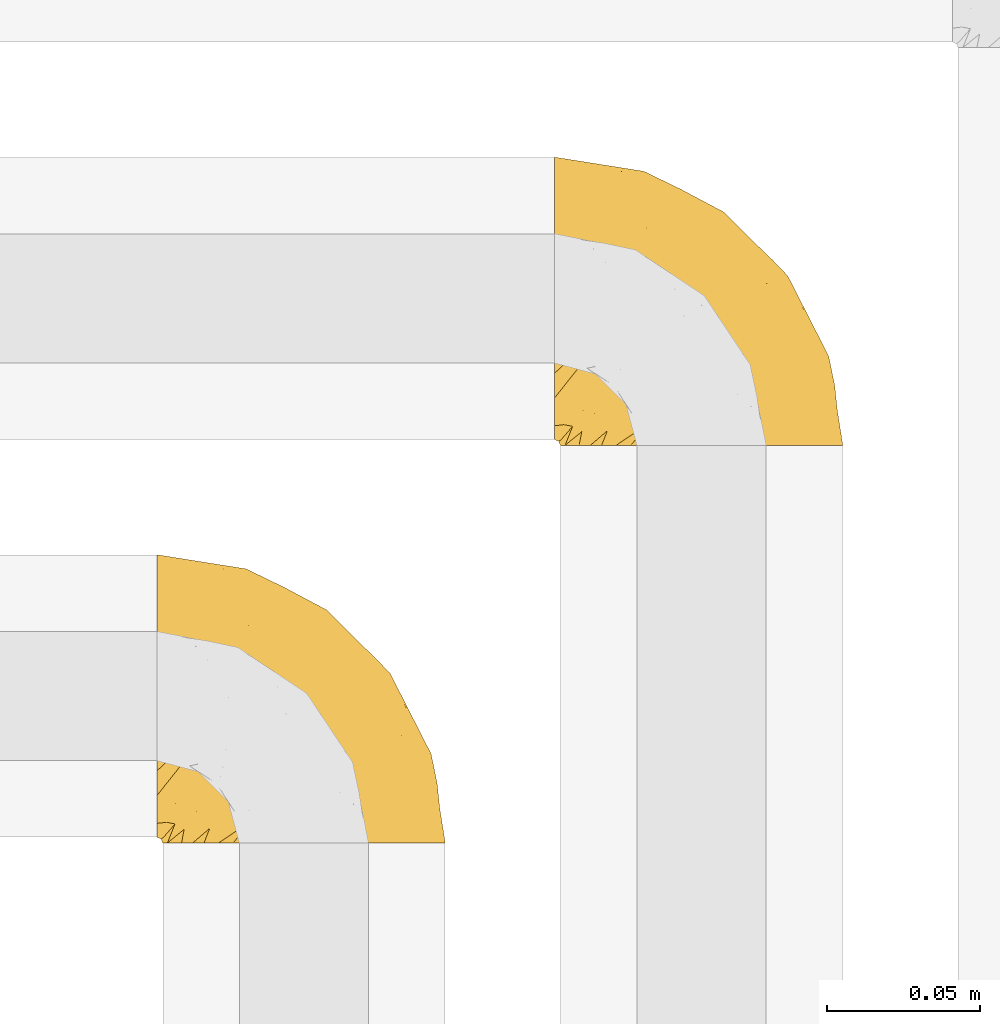
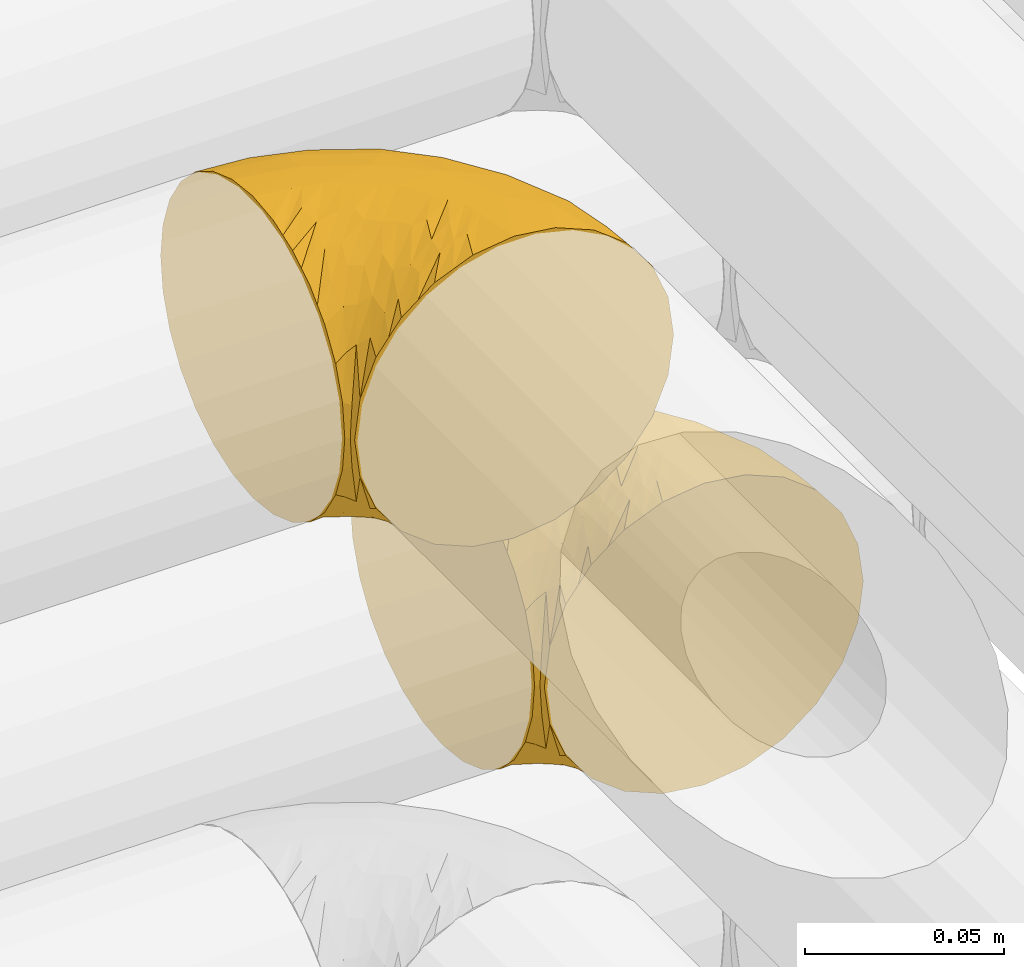
# One storey, part 180 of 827: 2 coverings.
"""IFC2X3 building model written with IfcOpenShell, lengths in millimetres."""

from ifc_helpers import new_model, entity, si_unit, converted_unit, derived_unit, direction, frame, origin, place, context, subcontext, project, spatial, faceted_brep, element, save


model = new_model("IFC2X3")

# Units and contexts
model_context = context("Model", 3, precision=0.01, world=origin(), true_north=direction((6.12303176911189e-17, 1.0)))
body_context = subcontext(model_context, "Body", "Model", "MODEL_VIEW")
ifc_project = project(units=[si_unit("LENGTHUNIT", "METRE", prefix="MILLI"), si_unit("AREAUNIT", "SQUARE_METRE"), si_unit("VOLUMEUNIT", "CUBIC_METRE"), converted_unit("PLANEANGLEUNIT", "DEGREE", entity("IfcRatioMeasure", 0.0174532925199433), si_unit("PLANEANGLEUNIT", "RADIAN"), dimensions=[0, 0, 0, 0, 0, 0, 0]), si_unit("MASSUNIT", "GRAM", prefix="KILO"), derived_unit("MASSDENSITYUNIT", [(si_unit("MASSUNIT", "GRAM", prefix="KILO"), 1), (si_unit("LENGTHUNIT", "METRE"), -3)]), derived_unit("MOMENTOFINERTIAUNIT", [(si_unit("LENGTHUNIT", "METRE"), 4)]), si_unit("TIMEUNIT", "SECOND"), si_unit("FREQUENCYUNIT", "HERTZ"), si_unit("THERMODYNAMICTEMPERATUREUNIT", "DEGREE_CELSIUS"), derived_unit("THERMALTRANSMITTANCEUNIT", [(si_unit("MASSUNIT", "GRAM", prefix="KILO"), 1), (si_unit("THERMODYNAMICTEMPERATUREUNIT", "KELVIN"), -1), (si_unit("TIMEUNIT", "SECOND"), -3)]), derived_unit("VOLUMETRICFLOWRATEUNIT", [(si_unit("LENGTHUNIT", "METRE"), 3), (si_unit("TIMEUNIT", "SECOND"), -1)]), derived_unit("MASSFLOWRATEUNIT", [(si_unit("MASSUNIT", "GRAM", prefix="KILO"), 1), (si_unit("TIMEUNIT", "SECOND"), -1)]), derived_unit("ROTATIONALFREQUENCYUNIT", [(si_unit("TIMEUNIT", "SECOND"), -1)]), si_unit("ELECTRICCURRENTUNIT", "AMPERE"), si_unit("ELECTRICVOLTAGEUNIT", "VOLT"), si_unit("POWERUNIT", "WATT"), si_unit("FORCEUNIT", "NEWTON", prefix="KILO"), si_unit("ILLUMINANCEUNIT", "LUX"), si_unit("LUMINOUSFLUXUNIT", "LUMEN"), si_unit("LUMINOUSINTENSITYUNIT", "CANDELA"), derived_unit("USERDEFINED", [(si_unit("MASSUNIT", "GRAM", prefix="KILO"), -1), (si_unit("LENGTHUNIT", "METRE"), -2), (si_unit("TIMEUNIT", "SECOND"), 3), (si_unit("LUMINOUSFLUXUNIT", "LUMEN"), 1)]), derived_unit("LINEARVELOCITYUNIT", [(si_unit("LENGTHUNIT", "METRE"), 1), (si_unit("TIMEUNIT", "SECOND"), -1)]), si_unit("PRESSUREUNIT", "PASCAL"), derived_unit("USERDEFINED", [(si_unit("LENGTHUNIT", "METRE"), -2), (si_unit("MASSUNIT", "GRAM", prefix="KILO"), 1), (si_unit("TIMEUNIT", "SECOND"), -2)]), derived_unit("LINEARFORCEUNIT", [(si_unit("MASSUNIT", "GRAM", prefix="KILO"), 1), (si_unit("LENGTHUNIT", "METRE"), 1), (si_unit("TIMEUNIT", "SECOND"), -2), (si_unit("LENGTHUNIT", "METRE"), -1)]), derived_unit("PLANARFORCEUNIT", [(si_unit("MASSUNIT", "GRAM", prefix="KILO"), 1), (si_unit("LENGTHUNIT", "METRE"), 1), (si_unit("TIMEUNIT", "SECOND"), -2), (si_unit("LENGTHUNIT", "METRE"), -2)])], contexts=[model_context])

# Site, building, storey
site_placement = place(None, origin())
site = spatial("IfcSite", under=ifc_project, at=site_placement, CompositionType="ELEMENT")
building_placement = place(site_placement, origin())
building = spatial("IfcBuilding", under=site, at=building_placement, CompositionType="ELEMENT")
storey_placement = place(building_placement, frame((0.0, 0.0, 28200.0)))
storey = spatial("IfcBuildingStorey", under=building, at=storey_placement, Name="08", CompositionType="ELEMENT", Elevation=28200.0)

# Coverings
covering_1_placement = place(storey_placement, frame((35420.44, 14180.41, 3152.2)))
element("IfcCovering", 1, at=covering_1_placement, inside=storey, Name=":ADSK_", ObjectType=":ADSK_", PredefinedType="INSULATION", context=body_context, shape_type="Brep", body=[
    faceted_brep([(1.6, 78.41, 83.91), (1.6, 85.72, 76.59), (1.6, 91.22, 67.83), (1.6, 94.64, 58.07), (1.6, 95.8, 47.8), (1.6, 94.64, 37.51), (1.6, 91.22, 27.74), (1.6, 85.71, 18.98), (1.6, 78.39, 11.67), (1.6, 69.63, 6.17), (1.6, 59.87, 2.75), (1.6, 49.6, 1.6), (1.6, 45.45, 2.06), (1.6, 42.38, 2.41), (1.6, 39.31, 2.75), (1.6, 34.43, 4.46), (1.6, 29.54, 6.17), (1.6, 25.16, 8.93), (1.6, 20.78, 11.68), (1.6, 17.13, 15.34), (1.6, 13.47, 19.0), (1.6, 7.97, 27.76), (1.6, 6.26, 32.64), (1.6, 4.55, 37.52), (1.6, 3.4, 47.8), (1.6, 4.55, 58.08), (1.6, 6.26, 62.96), (1.6, 7.97, 67.85), (1.6, 13.48, 76.61), (1.6, 17.14, 80.26), (1.6, 20.8, 83.92), (1.6, 25.18, 86.67), (1.6, 29.56, 89.42), (1.6, 34.44, 91.13), (1.6, 39.32, 92.84), (1.6, 42.39, 93.18), (1.6, 45.45, 93.53), (1.6, 49.6, 94.0), (1.6, 59.88, 92.84), (1.6, 69.65, 89.42), (3.4, 1.6, 47.8), (4.97, 1.6, 35.84), (9.58, 1.6, 24.7), (13.26, 1.6, 19.91), (16.93, 1.6, 15.13), (21.71, 1.6, 11.46), (26.5, 1.6, 7.78), (32.07, 1.6, 5.48), (37.64, 1.6, 3.17), (41.25, 1.6, 2.69), (43.34, 1.6, 2.42), (45.42, 1.6, 2.14), (49.6, 1.6, 1.6), (61.55, 1.6, 3.17), (72.7, 1.6, 7.78), (82.26, 1.6, 15.13), (89.61, 1.6, 24.7), (94.22, 1.6, 35.84), (95.8, 1.6, 47.8), (94.22, 1.6, 59.75), (89.61, 1.6, 70.9), (82.26, 1.6, 80.46), (72.7, 1.6, 87.81), (61.55, 1.6, 92.42), (49.6, 1.6, 94.0), (45.42, 1.6, 93.45), (41.25, 1.6, 92.9), (37.64, 1.6, 92.42), (32.07, 1.6, 90.11), (26.5, 1.6, 87.81), (21.71, 1.6, 84.13), (16.93, 1.6, 80.46), (13.26, 1.6, 75.68), (9.58, 1.6, 70.9), (4.97, 1.6, 59.75), (81.55, 36.81, 71.98), (90.4, 23.28, 63.6), (83.0, 45.8, 59.72), (91.18, 30.7, 47.8), (93.13, 21.2, 55.16), (94.0, 12.96, 47.8), (66.19, 66.19, 63.76), (70.92, 54.51, 72.22), (85.95, 17.98, 74.18), (49.74, 36.69, 92.52), (35.54, 35.54, 94.0), (38.14, 31.64, 94.0), (40.74, 27.75, 94.0), (43.34, 23.86, 94.0), (45.94, 19.96, 94.0), (77.59, 22.8, 82.14), (71.17, 42.67, 80.34), (65.81, 33.21, 87.52), (59.03, 59.45, 79.59), (45.85, 71.5, 78.25), (45.79, 62.66, 85.01), (41.42, 54.5, 90.25), (34.51, 47.57, 93.2), (56.04, 48.81, 87.23), (15.15, 74.98, 85.55), (56.51, 18.7, 93.0), (68.39, 15.75, 89.31), (23.33, 91.17, 61.31), (42.86, 85.28, 56.86), (39.42, 82.58, 68.34), (53.58, 75.78, 65.71), (59.17, 74.98, 56.99), (59.06, 67.27, 72.15), (22.63, 87.38, 70.34), (20.55, 82.04, 78.36), (12.96, 94.0, 47.8), (56.96, 77.8, 47.8), (67.38, 67.38, 47.8), (18.72, 56.2, 93.06), (5.33, 48.85, 94.0), (9.07, 48.11, 94.0), (11.79, 47.57, 94.0), (14.51, 47.03, 94.0), (17.24, 46.48, 94.0), (19.96, 45.94, 94.0), (21.03, 65.78, 89.88), (46.48, 17.24, 94.0), (47.03, 14.51, 94.0), (47.57, 11.79, 94.0), (48.11, 9.07, 94.0), (48.48, 7.2, 94.0), (48.85, 5.33, 94.0), (30.7, 91.18, 47.8), (23.86, 43.34, 94.0), (27.75, 40.74, 94.0), (31.64, 38.14, 94.0), (31.26, 72.73, 83.7), (77.8, 56.96, 47.8), (72.75, 62.23, 55.9), (43.83, 84.49, 47.8), (84.49, 43.83, 47.8), (14.58, 12.05, 81.75), (16.17, 18.95, 86.43), (10.82, 13.02, 79.8), (4.64, 8.34, 69.84), (7.71, 14.63, 79.5), (25.13, 11.09, 88.08), (32.66, 13.66, 91.6), (34.94, 20.08, 92.93), (36.76, 9.61, 92.43), (40.48, 9.48, 93.24), (39.25, 16.1, 93.36), (3.69, 3.42, 57.25), (13.99, 26.63, 89.41), (21.85, 33.72, 92.89), (17.93, 34.77, 92.66), (15.11, 6.75, 79.58), (21.14, 13.31, 86.51), (12.7, 21.11, 86.29), (7.21, 19.94, 83.91), (32.27, 8.67, 90.94), (25.68, 26.11, 91.94), (22.18, 29.3, 91.98), (18.79, 6.32, 82.79), (10.12, 39.92, 93.16), (9.47, 27.05, 88.76), (10.45, 6.04, 73.94), (11.29, 34.4, 91.89), (2.87, 2.87, 47.8), (31.16, 20.92, 92.22), (6.31, 27.43, 88.56), (25.62, 7.54, 87.72), (21.18, 18.45, 88.33), (28.81, 23.88, 92.18), (7.45, 7.77, 71.78), (21.14, 13.3, 9.09), (25.13, 11.09, 7.51), (18.79, 6.33, 12.8), (48.11, 9.07, 1.6), (48.85, 5.33, 1.6), (47.03, 14.51, 1.6), (47.57, 11.79, 1.6), (3.69, 3.42, 38.35), (7.44, 7.76, 23.84), (14.51, 47.03, 1.6), (11.79, 47.57, 1.6), (5.33, 48.85, 1.6), (9.07, 48.11, 1.6), (7.71, 14.62, 16.1), (9.47, 27.03, 6.84), (34.94, 20.08, 2.66), (31.16, 20.92, 3.37), (40.74, 27.75, 1.6), (38.14, 31.64, 1.6), (36.76, 9.61, 3.16), (40.48, 9.48, 2.35), (4.63, 8.33, 25.77), (15.11, 6.74, 16.02), (14.58, 12.04, 13.85), (43.34, 23.86, 1.6), (45.94, 19.96, 1.6), (39.25, 16.1, 2.23), (7.21, 19.93, 11.69), (12.69, 21.1, 9.31), (10.14, 39.92, 2.43), (21.81, 33.68, 2.71), (22.19, 29.28, 3.61), (14.0, 26.62, 6.18), (25.69, 26.08, 3.66), (16.17, 18.93, 9.17), (6.66, 27.87, 6.77), (17.92, 34.75, 2.93), (10.45, 6.04, 21.66), (31.64, 38.14, 1.6), (10.64, 12.79, 16.09), (11.31, 34.41, 3.7), (19.96, 45.94, 1.6), (23.86, 43.34, 1.6), (27.75, 40.74, 1.6), (32.66, 13.66, 3.99), (46.48, 17.24, 1.6), (32.27, 8.67, 4.65), (35.54, 35.54, 1.6), (28.77, 23.83, 3.43), (21.17, 18.43, 7.27), (23.36, 6.03, 9.46), (17.24, 46.48, 1.6), (47.58, 34.52, 2.4), (93.13, 21.2, 40.43), (77.44, 23.82, 13.57), (66.78, 41.32, 11.3), (71.68, 47.62, 18.65), (74.96, 52.66, 27.26), (81.55, 36.81, 23.61), (36.7, 49.75, 3.07), (56.9, 19.07, 2.69), (83.0, 45.8, 35.87), (90.4, 23.28, 31.99), (67.83, 21.35, 6.71), (85.95, 17.98, 21.41), (39.41, 82.57, 27.24), (23.33, 91.17, 34.26), (42.87, 85.27, 38.73), (53.92, 73.89, 26.97), (66.19, 66.19, 31.83), (64.12, 62.43, 23.4), (33.13, 63.53, 6.91), (23.1, 58.45, 3.4), (16.98, 67.16, 5.84), (55.72, 76.72, 35.73), (72.75, 62.22, 39.69), (23.77, 81.54, 17.6), (18.41, 74.8, 10.38), (43.7, 75.83, 20.6), (54.53, 41.45, 5.36), (17.73, 88.2, 24.84), (38.98, 71.6, 13.87), (50.28, 56.23, 9.06), (59.02, 59.44, 15.99)], [[[0, 1, 2, 3, 4, 5, 6, 7, 8, 9, 10, 11, 12, 13, 14, 15, 16, 17, 18, 19, 20, 21, 22, 23, 24, 25, 26, 27, 28, 29, 30, 31, 32, 33, 34, 35, 36, 37, 38, 39]], [[40, 41, 42, 43, 44, 45, 46, 47, 48, 49, 50, 51, 52, 53, 54, 55, 56, 57, 58, 59, 60, 61, 62, 63, 64, 65, 66, 67, 68, 69, 70, 71, 72, 73, 74]], [[75, 76, 77]], [[78, 79, 80]], [[77, 81, 82]], [[76, 75, 83]], [[84, 85, 86, 87, 88, 89]], [[90, 91, 92]], [[76, 60, 59]], [[93, 94, 95]], [[90, 62, 61]], [[83, 61, 60]], [[96, 97, 84]], [[98, 93, 95]], [[0, 39, 99]], [[100, 84, 89]], [[62, 101, 63]], [[2, 102, 3]], [[92, 84, 100]], [[103, 102, 104]], [[103, 105, 106]], [[93, 107, 94]], [[1, 108, 2]], [[92, 101, 90]], [[108, 1, 109]], [[102, 110, 3]], [[93, 82, 107]], [[102, 108, 104]], [[111, 106, 112]], [[109, 0, 99]], [[113, 37, 114, 115, 116, 117, 118, 119]], [[120, 38, 113]], [[100, 89, 121, 122, 123, 124, 125, 126, 64]], [[127, 102, 103]], [[97, 119, 128, 129, 130, 85]], [[99, 120, 131]], [[132, 133, 77]], [[59, 80, 79]], [[1, 0, 109]], [[98, 84, 92]], [[94, 109, 131]], [[120, 39, 38]], [[93, 91, 82]], [[104, 94, 105]], [[97, 113, 119]], [[95, 120, 96]], [[83, 90, 61]], [[91, 93, 98]], [[64, 63, 100]], [[100, 63, 101]], [[77, 76, 79]], [[133, 106, 81]], [[84, 97, 85]], [[113, 96, 120]], [[113, 97, 96]], [[37, 113, 38]], [[110, 102, 127]], [[110, 4, 3]], [[103, 111, 134, 127]], [[90, 75, 91]], [[82, 81, 107]], [[91, 75, 82]], [[77, 82, 75]], [[76, 83, 60]], [[90, 83, 75]], [[105, 107, 81]], [[94, 131, 95]], [[105, 94, 107]], [[109, 94, 104]], [[120, 95, 131]], [[98, 95, 96]], [[84, 98, 96]], [[98, 92, 91]], [[106, 105, 81]], [[103, 104, 105]], [[112, 106, 133]], [[103, 106, 111]], [[112, 133, 132]], [[81, 77, 133]], [[77, 78, 135, 132]], [[120, 99, 39]], [[109, 99, 131]], [[59, 58, 80]], [[59, 79, 76]], [[90, 101, 62]], [[100, 101, 92]], [[2, 108, 102]], [[109, 104, 108]], [[78, 77, 79]], [[136, 137, 138]], [[27, 139, 140]], [[141, 142, 143]], [[144, 145, 121]], [[146, 89, 88]], [[147, 139, 25]], [[148, 149, 150]], [[136, 151, 152]], [[147, 40, 74]], [[24, 147, 25]], [[140, 153, 154]], [[33, 116, 34]], [[73, 72, 151]], [[114, 37, 36, 35, 34, 116, 115]], [[146, 155, 144]], [[156, 85, 130]], [[157, 149, 148]], [[151, 158, 152]], [[117, 33, 159]], [[29, 154, 160]], [[161, 74, 73]], [[162, 128, 119]], [[66, 65, 64, 126, 125, 124, 123, 122, 67]], [[163, 147, 24]], [[27, 140, 28]], [[149, 129, 150]], [[139, 27, 26, 25]], [[68, 144, 69]], [[129, 128, 150]], [[164, 87, 86]], [[130, 129, 149]], [[122, 145, 67]], [[154, 153, 148]], [[162, 119, 159]], [[165, 30, 160]], [[150, 160, 148]], [[128, 162, 150]], [[30, 165, 31]], [[145, 144, 68]], [[89, 146, 144]], [[87, 164, 143]], [[166, 155, 142]], [[88, 87, 143]], [[162, 160, 150]], [[160, 30, 29]], [[154, 29, 28]], [[140, 154, 28]], [[160, 154, 148]], [[140, 137, 153]], [[157, 148, 153]], [[156, 130, 157]], [[153, 137, 157]], [[157, 137, 156]], [[167, 137, 136]], [[168, 85, 156]], [[152, 168, 167]], [[167, 168, 156]], [[164, 152, 141]], [[71, 158, 72]], [[152, 167, 136]], [[88, 142, 146]], [[144, 155, 69]], [[146, 142, 155]], [[70, 166, 71]], [[142, 141, 166]], [[70, 69, 155]], [[141, 158, 71]], [[161, 73, 151]], [[138, 137, 140]], [[161, 136, 169]], [[136, 161, 151]], [[74, 161, 169]], [[152, 158, 141]], [[151, 72, 158]], [[168, 152, 164]], [[137, 167, 156]], [[164, 86, 168]], [[85, 168, 86]], [[116, 33, 117]], [[130, 149, 157]], [[67, 145, 68]], [[121, 89, 144]], [[145, 122, 121]], [[40, 147, 163]], [[169, 147, 74]], [[159, 33, 32]], [[162, 159, 32]], [[159, 119, 118, 117]], [[139, 147, 169]], [[139, 169, 138]], [[162, 32, 31]], [[141, 143, 164]], [[88, 143, 142]], [[71, 166, 141]], [[155, 166, 70]], [[139, 138, 140]], [[169, 136, 138]], [[160, 162, 165]], [[162, 31, 165]], [[170, 171, 172]], [[173, 174, 52, 51, 50, 49, 48, 175, 176]], [[177, 178, 41]], [[179, 15, 180]], [[12, 11, 181, 182, 180, 14, 13]], [[183, 21, 20]], [[19, 18, 184]], [[185, 186, 187]], [[186, 188, 187]], [[43, 172, 44]], [[189, 190, 47]], [[23, 22, 21, 191]], [[170, 192, 193]], [[40, 163, 177]], [[194, 195, 196]], [[24, 23, 177]], [[197, 198, 183]], [[199, 15, 179]], [[47, 46, 189]], [[200, 201, 202]], [[201, 203, 204]], [[205, 206, 184]], [[207, 41, 178]], [[16, 15, 199]], [[14, 180, 15]], [[202, 201, 198]], [[208, 201, 200]], [[163, 24, 177]], [[48, 47, 190]], [[196, 195, 189]], [[197, 184, 202]], [[204, 193, 209]], [[210, 211, 212]], [[206, 212, 213]], [[205, 17, 210]], [[184, 206, 202]], [[210, 212, 206]], [[185, 194, 214]], [[189, 215, 190]], [[216, 45, 214]], [[186, 171, 170]], [[189, 216, 196]], [[197, 20, 19]], [[194, 185, 187]], [[197, 183, 20]], [[184, 197, 19]], [[197, 202, 198]], [[206, 200, 202]], [[204, 183, 198]], [[201, 208, 203]], [[203, 208, 217]], [[204, 198, 201]], [[217, 188, 218]], [[193, 219, 170]], [[171, 186, 185]], [[170, 218, 186]], [[170, 219, 218]], [[42, 207, 192]], [[171, 220, 172]], [[216, 189, 46]], [[214, 194, 196]], [[44, 220, 45]], [[214, 196, 216]], [[216, 46, 45]], [[214, 45, 220]], [[192, 43, 42]], [[204, 203, 219]], [[207, 193, 192]], [[209, 193, 178]], [[41, 207, 42]], [[193, 207, 178]], [[43, 192, 172]], [[170, 172, 192]], [[204, 219, 193]], [[219, 203, 218]], [[217, 218, 203]], [[188, 186, 218]], [[206, 213, 200]], [[208, 200, 213]], [[199, 210, 16]], [[215, 189, 195]], [[215, 175, 190]], [[175, 48, 190]], [[199, 179, 221, 211]], [[210, 199, 211]], [[23, 191, 177]], [[40, 177, 41]], [[178, 177, 191]], [[21, 183, 191]], [[209, 191, 183]], [[205, 18, 17]], [[17, 16, 210]], [[171, 185, 214]], [[172, 220, 44]], [[214, 220, 171]], [[191, 209, 178]], [[204, 209, 183]], [[206, 205, 210]], [[18, 205, 184]], [[222, 195, 194, 187, 188, 217]], [[57, 223, 80]], [[224, 225, 226]], [[226, 227, 228]], [[229, 217, 208, 213, 212, 211]], [[230, 52, 174, 173, 176, 175, 215, 195]], [[231, 232, 228]], [[231, 78, 223]], [[223, 57, 232]], [[224, 233, 225]], [[233, 54, 53]], [[234, 232, 56]], [[56, 55, 234]], [[234, 224, 228]], [[235, 236, 237]], [[224, 55, 54]], [[238, 239, 240]], [[52, 230, 53]], [[241, 242, 243]], [[239, 244, 245]], [[11, 10, 242]], [[236, 6, 5]], [[7, 246, 8]], [[8, 247, 9]], [[238, 248, 235]], [[222, 229, 249]], [[242, 211, 221, 179, 180, 182, 181, 11]], [[233, 53, 230]], [[111, 112, 244]], [[250, 6, 236]], [[247, 251, 241]], [[6, 250, 7]], [[127, 236, 110]], [[249, 229, 252]], [[247, 8, 246]], [[235, 246, 250]], [[236, 5, 110]], [[235, 244, 238]], [[237, 236, 127]], [[243, 9, 247]], [[252, 229, 241]], [[56, 232, 57]], [[222, 230, 195]], [[225, 249, 252]], [[249, 233, 230]], [[54, 233, 224]], [[231, 228, 227]], [[245, 132, 231]], [[249, 225, 233]], [[226, 225, 253]], [[235, 250, 236]], [[246, 7, 250]], [[251, 247, 246]], [[243, 247, 241]], [[248, 246, 235]], [[252, 251, 253]], [[229, 222, 217]], [[230, 222, 249]], [[5, 4, 110]], [[237, 127, 134, 111]], [[238, 244, 239]], [[224, 234, 55]], [[232, 234, 228]], [[242, 241, 229]], [[10, 9, 243]], [[211, 242, 229]], [[10, 243, 242]], [[80, 223, 78]], [[80, 58, 57]], [[231, 223, 232]], [[227, 240, 239]], [[224, 226, 228]], [[240, 226, 253]], [[227, 239, 245]], [[226, 240, 227]], [[251, 248, 253]], [[240, 253, 248]], [[244, 235, 237]], [[237, 111, 244]], [[132, 245, 112]], [[112, 245, 244]], [[135, 78, 231, 132]], [[227, 245, 231]], [[248, 238, 240]], [[246, 248, 251]], [[251, 252, 241]], [[225, 252, 253]]]),
])
covering_2_placement = place(storey_placement, frame((35290.44, 14050.41, 3352.2)))
element("IfcCovering", 2, at=covering_2_placement, inside=storey, Name=":ADSK_", ObjectType=":ADSK_", PredefinedType="INSULATION", context=body_context, shape_type="Brep", body=[
    faceted_brep([(1.6, 78.41, 83.91), (1.6, 85.72, 76.59), (1.6, 91.22, 67.83), (1.6, 94.64, 58.07), (1.6, 95.8, 47.8), (1.6, 94.64, 37.51), (1.6, 91.22, 27.74), (1.6, 85.71, 18.98), (1.6, 78.39, 11.67), (1.6, 69.63, 6.17), (1.6, 59.87, 2.75), (1.6, 49.6, 1.6), (1.6, 45.45, 2.06), (1.6, 42.38, 2.41), (1.6, 39.31, 2.75), (1.6, 34.43, 4.46), (1.6, 29.54, 6.17), (1.6, 25.16, 8.93), (1.6, 20.78, 11.68), (1.6, 17.13, 15.34), (1.6, 13.47, 19.0), (1.6, 7.97, 27.76), (1.6, 6.26, 32.64), (1.6, 4.55, 37.52), (1.6, 3.4, 47.8), (1.6, 4.55, 58.08), (1.6, 6.26, 62.96), (1.6, 7.97, 67.85), (1.6, 13.48, 76.61), (1.6, 17.14, 80.26), (1.6, 20.8, 83.92), (1.6, 25.18, 86.67), (1.6, 29.56, 89.42), (1.6, 34.44, 91.13), (1.6, 39.32, 92.84), (1.6, 42.39, 93.18), (1.6, 45.45, 93.53), (1.6, 49.6, 94.0), (1.6, 59.88, 92.84), (1.6, 69.65, 89.42), (3.4, 1.6, 47.8), (4.97, 1.6, 35.84), (9.58, 1.6, 24.7), (13.26, 1.6, 19.91), (16.93, 1.6, 15.13), (21.71, 1.6, 11.46), (26.5, 1.6, 7.78), (32.07, 1.6, 5.48), (37.64, 1.6, 3.17), (41.25, 1.6, 2.69), (43.34, 1.6, 2.42), (45.42, 1.6, 2.14), (49.6, 1.6, 1.6), (61.55, 1.6, 3.17), (72.7, 1.6, 7.78), (82.26, 1.6, 15.13), (89.61, 1.6, 24.7), (94.22, 1.6, 35.84), (95.8, 1.6, 47.8), (94.22, 1.6, 59.75), (89.61, 1.6, 70.9), (82.26, 1.6, 80.46), (72.7, 1.6, 87.81), (61.55, 1.6, 92.42), (49.6, 1.6, 94.0), (45.42, 1.6, 93.45), (41.25, 1.6, 92.9), (37.64, 1.6, 92.42), (32.07, 1.6, 90.11), (26.5, 1.6, 87.81), (21.71, 1.6, 84.13), (16.93, 1.6, 80.46), (13.26, 1.6, 75.68), (9.58, 1.6, 70.9), (4.97, 1.6, 59.75), (81.55, 36.81, 71.98), (90.4, 23.28, 63.6), (83.0, 45.8, 59.72), (91.18, 30.7, 47.8), (93.13, 21.2, 55.16), (94.0, 12.96, 47.8), (66.19, 66.19, 63.76), (70.92, 54.51, 72.22), (85.95, 17.98, 74.18), (49.74, 36.69, 92.52), (35.54, 35.54, 94.0), (38.14, 31.64, 94.0), (40.74, 27.75, 94.0), (43.34, 23.86, 94.0), (45.94, 19.96, 94.0), (77.59, 22.8, 82.14), (71.17, 42.67, 80.34), (65.81, 33.21, 87.52), (59.03, 59.45, 79.59), (45.85, 71.5, 78.25), (45.79, 62.66, 85.01), (41.42, 54.5, 90.25), (34.51, 47.57, 93.2), (56.04, 48.81, 87.23), (15.15, 74.98, 85.55), (56.51, 18.7, 93.0), (68.39, 15.75, 89.31), (23.33, 91.17, 61.31), (42.86, 85.28, 56.86), (39.42, 82.58, 68.34), (53.58, 75.78, 65.71), (59.17, 74.98, 56.99), (59.06, 67.27, 72.15), (22.63, 87.38, 70.34), (20.55, 82.04, 78.36), (12.96, 94.0, 47.8), (56.96, 77.8, 47.8), (67.38, 67.38, 47.8), (18.72, 56.2, 93.06), (5.33, 48.85, 94.0), (9.07, 48.11, 94.0), (11.79, 47.57, 94.0), (14.51, 47.03, 94.0), (17.24, 46.48, 94.0), (19.96, 45.94, 94.0), (21.03, 65.78, 89.88), (46.48, 17.24, 94.0), (47.03, 14.51, 94.0), (47.57, 11.79, 94.0), (48.11, 9.07, 94.0), (48.48, 7.2, 94.0), (48.85, 5.33, 94.0), (30.7, 91.18, 47.8), (23.86, 43.34, 94.0), (27.75, 40.74, 94.0), (31.64, 38.14, 94.0), (31.26, 72.73, 83.7), (77.8, 56.96, 47.8), (72.75, 62.23, 55.9), (43.83, 84.49, 47.8), (84.49, 43.83, 47.8), (14.58, 12.05, 81.75), (16.17, 18.95, 86.43), (10.82, 13.02, 79.8), (4.64, 8.34, 69.84), (7.71, 14.63, 79.5), (25.13, 11.09, 88.08), (32.66, 13.66, 91.6), (34.94, 20.08, 92.93), (36.76, 9.61, 92.43), (40.48, 9.48, 93.24), (39.25, 16.1, 93.36), (3.69, 3.42, 57.25), (13.99, 26.63, 89.41), (21.85, 33.72, 92.89), (17.93, 34.77, 92.66), (15.11, 6.75, 79.58), (21.14, 13.31, 86.51), (12.7, 21.11, 86.29), (7.21, 19.94, 83.91), (32.27, 8.67, 90.94), (25.68, 26.11, 91.94), (22.18, 29.3, 91.98), (18.79, 6.32, 82.79), (10.12, 39.92, 93.16), (9.47, 27.05, 88.76), (10.45, 6.04, 73.94), (11.29, 34.4, 91.89), (2.87, 2.87, 47.8), (31.16, 20.92, 92.22), (6.31, 27.43, 88.56), (25.62, 7.54, 87.72), (21.18, 18.45, 88.33), (28.81, 23.88, 92.18), (7.45, 7.77, 71.78), (21.17, 18.43, 7.27), (16.17, 18.93, 9.17), (25.69, 26.08, 3.66), (48.11, 9.07, 1.6), (48.85, 5.33, 1.6), (47.03, 14.51, 1.6), (47.57, 11.79, 1.6), (3.69, 3.42, 38.35), (7.44, 7.76, 23.84), (14.51, 47.03, 1.6), (11.79, 47.57, 1.6), (5.33, 48.85, 1.6), (9.07, 48.11, 1.6), (7.71, 14.62, 16.1), (9.47, 27.03, 6.84), (34.94, 20.08, 2.66), (31.16, 20.92, 3.37), (40.74, 27.75, 1.6), (38.14, 31.64, 1.6), (18.79, 6.33, 12.8), (36.76, 9.61, 3.16), (40.48, 9.48, 2.35), (4.63, 8.33, 25.77), (21.14, 13.3, 9.09), (15.11, 6.74, 16.02), (14.58, 12.04, 13.85), (43.34, 23.86, 1.6), (45.94, 19.96, 1.6), (39.25, 16.1, 2.23), (7.21, 19.93, 11.69), (12.69, 21.1, 9.31), (10.14, 39.92, 2.43), (21.81, 33.68, 2.71), (22.19, 29.28, 3.61), (14.0, 26.62, 6.18), (6.66, 27.87, 6.77), (17.92, 34.75, 2.93), (10.45, 6.04, 21.66), (31.64, 38.14, 1.6), (10.64, 12.79, 16.09), (11.31, 34.41, 3.7), (19.96, 45.94, 1.6), (23.86, 43.34, 1.6), (27.75, 40.74, 1.6), (32.66, 13.66, 3.99), (46.48, 17.24, 1.6), (32.27, 8.67, 4.65), (25.13, 11.09, 7.51), (35.54, 35.54, 1.6), (28.77, 23.83, 3.43), (23.36, 6.03, 9.46), (17.24, 46.48, 1.6), (47.58, 34.52, 2.4), (93.13, 21.2, 40.43), (77.44, 23.82, 13.57), (66.78, 41.32, 11.3), (71.68, 47.62, 18.65), (74.96, 52.66, 27.26), (81.55, 36.81, 23.61), (36.7, 49.75, 3.07), (56.9, 19.07, 2.69), (83.0, 45.8, 35.87), (90.4, 23.28, 31.99), (67.83, 21.35, 6.71), (85.95, 17.98, 21.41), (39.41, 82.57, 27.24), (23.33, 91.17, 34.26), (42.87, 85.27, 38.73), (53.92, 73.89, 26.97), (66.19, 66.19, 31.83), (64.12, 62.43, 23.4), (33.13, 63.53, 6.91), (23.1, 58.45, 3.4), (16.98, 67.16, 5.84), (72.75, 62.22, 39.69), (23.77, 81.54, 17.6), (18.41, 74.8, 10.38), (43.7, 75.83, 20.6), (54.53, 41.45, 5.36), (55.72, 76.72, 35.73), (17.73, 88.2, 24.84), (38.98, 71.6, 13.87), (50.28, 56.23, 9.06), (59.02, 59.44, 15.99)], [[[0, 1, 2, 3, 4, 5, 6, 7, 8, 9, 10, 11, 12, 13, 14, 15, 16, 17, 18, 19, 20, 21, 22, 23, 24, 25, 26, 27, 28, 29, 30, 31, 32, 33, 34, 35, 36, 37, 38, 39]], [[40, 41, 42, 43, 44, 45, 46, 47, 48, 49, 50, 51, 52, 53, 54, 55, 56, 57, 58, 59, 60, 61, 62, 63, 64, 65, 66, 67, 68, 69, 70, 71, 72, 73, 74]], [[75, 76, 77]], [[78, 79, 80]], [[77, 81, 82]], [[76, 75, 83]], [[84, 85, 86, 87, 88, 89]], [[90, 91, 92]], [[76, 60, 59]], [[93, 94, 95]], [[90, 62, 61]], [[83, 61, 60]], [[96, 97, 84]], [[98, 93, 95]], [[0, 39, 99]], [[100, 84, 89]], [[62, 101, 63]], [[2, 102, 3]], [[92, 84, 100]], [[103, 102, 104]], [[103, 105, 106]], [[93, 107, 94]], [[1, 108, 2]], [[92, 101, 90]], [[108, 1, 109]], [[102, 110, 3]], [[93, 82, 107]], [[102, 108, 104]], [[111, 106, 112]], [[109, 0, 99]], [[113, 37, 114, 115, 116, 117, 118, 119]], [[120, 38, 113]], [[100, 89, 121, 122, 123, 124, 125, 126, 64]], [[127, 102, 103]], [[97, 119, 128, 129, 130, 85]], [[99, 120, 131]], [[132, 133, 77]], [[59, 80, 79]], [[1, 0, 109]], [[98, 84, 92]], [[94, 109, 131]], [[120, 39, 38]], [[93, 91, 82]], [[104, 94, 105]], [[97, 113, 119]], [[95, 120, 96]], [[83, 90, 61]], [[91, 93, 98]], [[64, 63, 100]], [[100, 63, 101]], [[77, 76, 79]], [[133, 106, 81]], [[84, 97, 85]], [[113, 96, 120]], [[113, 97, 96]], [[37, 113, 38]], [[110, 102, 127]], [[110, 4, 3]], [[103, 111, 134, 127]], [[90, 75, 91]], [[82, 81, 107]], [[91, 75, 82]], [[77, 82, 75]], [[76, 83, 60]], [[90, 83, 75]], [[105, 107, 81]], [[94, 131, 95]], [[105, 94, 107]], [[109, 94, 104]], [[120, 95, 131]], [[98, 95, 96]], [[84, 98, 96]], [[98, 92, 91]], [[106, 105, 81]], [[103, 104, 105]], [[112, 106, 133]], [[103, 106, 111]], [[112, 133, 132]], [[81, 77, 133]], [[77, 78, 135, 132]], [[120, 99, 39]], [[109, 99, 131]], [[59, 58, 80]], [[59, 79, 76]], [[90, 101, 62]], [[100, 101, 92]], [[2, 108, 102]], [[109, 104, 108]], [[78, 77, 79]], [[136, 137, 138]], [[27, 139, 140]], [[141, 142, 143]], [[144, 145, 121]], [[146, 89, 88]], [[147, 139, 25]], [[148, 149, 150]], [[136, 151, 152]], [[147, 40, 74]], [[24, 147, 25]], [[140, 153, 154]], [[33, 116, 34]], [[73, 72, 151]], [[114, 37, 36, 35, 34, 116, 115]], [[146, 155, 144]], [[156, 85, 130]], [[157, 149, 148]], [[151, 158, 152]], [[117, 33, 159]], [[29, 154, 160]], [[161, 74, 73]], [[162, 128, 119]], [[66, 65, 64, 126, 125, 124, 123, 122, 67]], [[163, 147, 24]], [[27, 140, 28]], [[149, 129, 150]], [[139, 27, 26, 25]], [[68, 144, 69]], [[129, 128, 150]], [[164, 87, 86]], [[130, 129, 149]], [[122, 145, 67]], [[154, 153, 148]], [[162, 119, 159]], [[165, 30, 160]], [[150, 160, 148]], [[128, 162, 150]], [[30, 165, 31]], [[145, 144, 68]], [[89, 146, 144]], [[87, 164, 143]], [[166, 155, 142]], [[88, 87, 143]], [[162, 160, 150]], [[160, 30, 29]], [[154, 29, 28]], [[140, 154, 28]], [[160, 154, 148]], [[140, 137, 153]], [[157, 148, 153]], [[156, 130, 157]], [[153, 137, 157]], [[157, 137, 156]], [[167, 137, 136]], [[168, 85, 156]], [[152, 168, 167]], [[167, 168, 156]], [[164, 152, 141]], [[71, 158, 72]], [[152, 167, 136]], [[88, 142, 146]], [[144, 155, 69]], [[146, 142, 155]], [[70, 166, 71]], [[142, 141, 166]], [[70, 69, 155]], [[141, 158, 71]], [[161, 73, 151]], [[138, 137, 140]], [[161, 136, 169]], [[136, 161, 151]], [[74, 161, 169]], [[152, 158, 141]], [[151, 72, 158]], [[168, 152, 164]], [[137, 167, 156]], [[164, 86, 168]], [[85, 168, 86]], [[116, 33, 117]], [[130, 149, 157]], [[67, 145, 68]], [[121, 89, 144]], [[145, 122, 121]], [[40, 147, 163]], [[169, 147, 74]], [[159, 33, 32]], [[162, 159, 32]], [[159, 119, 118, 117]], [[139, 147, 169]], [[139, 169, 138]], [[162, 32, 31]], [[141, 143, 164]], [[88, 143, 142]], [[71, 166, 141]], [[155, 166, 70]], [[139, 138, 140]], [[169, 136, 138]], [[160, 162, 165]], [[162, 31, 165]], [[170, 171, 172]], [[173, 174, 52, 51, 50, 49, 48, 175, 176]], [[177, 178, 41]], [[179, 15, 180]], [[12, 11, 181, 182, 180, 14, 13]], [[183, 21, 20]], [[19, 18, 184]], [[185, 186, 187]], [[186, 188, 187]], [[43, 189, 44]], [[190, 191, 47]], [[23, 22, 21, 192]], [[193, 194, 195]], [[40, 163, 177]], [[196, 197, 198]], [[24, 23, 177]], [[199, 200, 183]], [[201, 15, 179]], [[178, 177, 192]], [[47, 46, 190]], [[202, 203, 204]], [[203, 172, 171]], [[205, 206, 184]], [[207, 41, 178]], [[16, 15, 201]], [[14, 180, 15]], [[204, 203, 200]], [[208, 203, 202]], [[163, 24, 177]], [[48, 47, 191]], [[198, 197, 190]], [[199, 184, 204]], [[171, 195, 209]], [[210, 211, 212]], [[206, 212, 213]], [[205, 17, 210]], [[184, 206, 204]], [[210, 212, 206]], [[185, 196, 214]], [[190, 215, 191]], [[216, 45, 214]], [[186, 217, 193]], [[190, 216, 198]], [[19, 184, 199]], [[196, 185, 187]], [[19, 199, 20]], [[200, 199, 204]], [[183, 20, 199]], [[206, 202, 204]], [[171, 183, 200]], [[203, 208, 172]], [[172, 208, 218]], [[171, 200, 203]], [[218, 188, 219]], [[195, 170, 193]], [[217, 186, 185]], [[193, 219, 186]], [[193, 170, 219]], [[207, 194, 42]], [[217, 220, 189]], [[216, 190, 46]], [[214, 196, 198]], [[44, 220, 45]], [[214, 198, 216]], [[216, 46, 45]], [[214, 45, 220]], [[42, 194, 43]], [[189, 193, 217]], [[207, 195, 194]], [[209, 195, 178]], [[41, 207, 42]], [[195, 207, 178]], [[43, 194, 189]], [[193, 189, 194]], [[171, 170, 195]], [[170, 172, 219]], [[218, 219, 172]], [[188, 186, 219]], [[206, 213, 202]], [[208, 202, 213]], [[201, 210, 16]], [[215, 190, 197]], [[215, 175, 191]], [[175, 48, 191]], [[201, 179, 221, 211]], [[210, 201, 211]], [[23, 192, 177]], [[40, 177, 41]], [[192, 183, 209]], [[21, 183, 192]], [[205, 18, 17]], [[17, 16, 210]], [[217, 185, 214]], [[189, 220, 44]], [[214, 220, 217]], [[192, 209, 178]], [[171, 209, 183]], [[206, 205, 210]], [[18, 205, 184]], [[222, 197, 196, 187, 188, 218]], [[57, 223, 80]], [[224, 225, 226]], [[226, 227, 228]], [[229, 218, 208, 213, 212, 211]], [[230, 52, 174, 173, 176, 175, 215, 197]], [[231, 232, 228]], [[231, 78, 223]], [[223, 57, 232]], [[224, 233, 225]], [[233, 54, 53]], [[234, 232, 56]], [[56, 55, 234]], [[234, 224, 228]], [[235, 236, 237]], [[224, 55, 54]], [[238, 239, 240]], [[52, 230, 53]], [[241, 242, 243]], [[231, 227, 244]], [[11, 10, 242]], [[236, 6, 5]], [[7, 245, 8]], [[8, 246, 9]], [[238, 247, 235]], [[222, 229, 248]], [[242, 211, 221, 179, 180, 182, 181, 11]], [[233, 53, 230]], [[111, 112, 249]], [[250, 6, 236]], [[246, 251, 241]], [[6, 250, 7]], [[127, 236, 110]], [[248, 229, 252]], [[246, 8, 245]], [[235, 245, 250]], [[236, 5, 110]], [[235, 249, 238]], [[237, 236, 127]], [[243, 9, 246]], [[252, 229, 241]], [[56, 232, 57]], [[222, 230, 197]], [[225, 248, 252]], [[248, 233, 230]], [[54, 233, 224]], [[231, 228, 227]], [[244, 132, 231]], [[248, 225, 233]], [[226, 225, 253]], [[235, 250, 236]], [[245, 7, 250]], [[251, 246, 245]], [[243, 246, 241]], [[247, 245, 235]], [[252, 251, 253]], [[229, 222, 218]], [[230, 222, 248]], [[5, 4, 110]], [[237, 127, 134, 111]], [[238, 249, 239]], [[224, 234, 55]], [[232, 234, 228]], [[242, 241, 229]], [[10, 9, 243]], [[211, 242, 229]], [[10, 243, 242]], [[80, 223, 78]], [[80, 58, 57]], [[231, 223, 232]], [[227, 240, 239]], [[224, 226, 228]], [[240, 226, 253]], [[227, 239, 244]], [[226, 240, 227]], [[251, 247, 253]], [[240, 253, 247]], [[249, 235, 237]], [[237, 111, 249]], [[244, 239, 249]], [[112, 244, 249]], [[135, 78, 231, 132]], [[112, 132, 244]], [[247, 238, 240]], [[245, 247, 251]], [[251, 252, 241]], [[225, 252, 253]]]),
])

save(model, "model.ifc")
